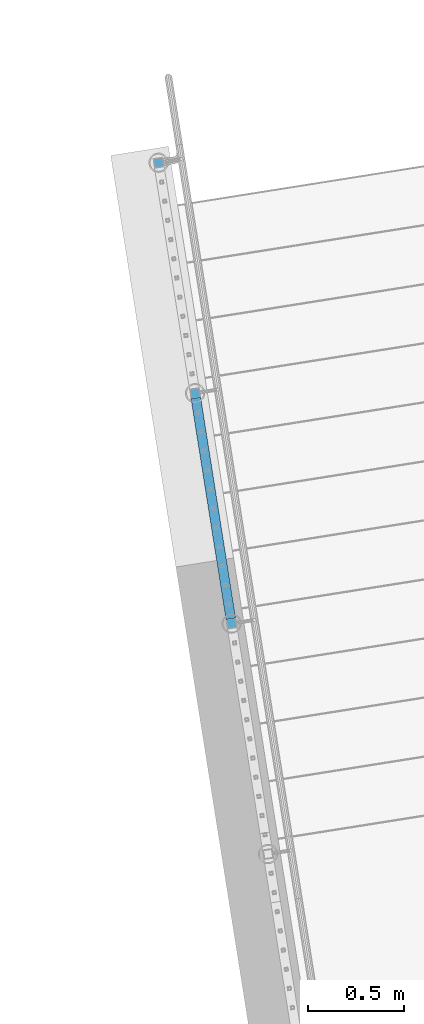
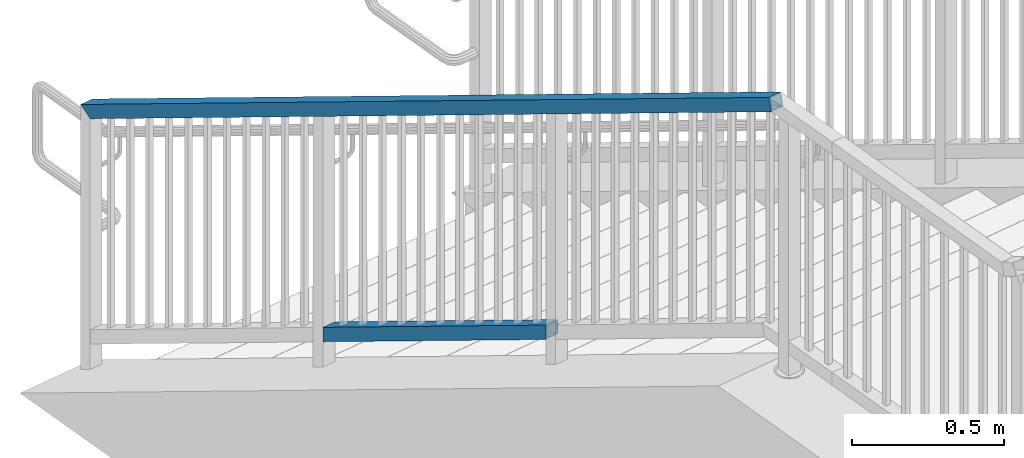
# One storey, part 323 of 975: 2 members.
"""IFC2X3 building model written with IfcOpenShell, lengths in millimetres."""

from ifc_helpers import new_model, si_unit, frame, origin_with_axes, place, context, subcontext, project, spatial, faceted_brep, material, type_object, element, save


model = new_model("IFC2X3")

# Units and contexts
model_context = context("Model", 3, precision=1e-05, world=origin_with_axes())
body_context = subcontext(model_context, "Body", "Model", "MODEL_VIEW")
ifc_project = project(units=[si_unit("LENGTHUNIT", "METRE", prefix="MILLI"), si_unit("AREAUNIT", "SQUARE_METRE"), si_unit("VOLUMEUNIT", "CUBIC_METRE"), si_unit("MASSUNIT", "GRAM", prefix="KILO"), si_unit("TIMEUNIT", "SECOND"), si_unit("PLANEANGLEUNIT", "RADIAN"), si_unit("SOLIDANGLEUNIT", "STERADIAN"), si_unit("THERMODYNAMICTEMPERATUREUNIT", "DEGREE_CELSIUS"), si_unit("LUMINOUSINTENSITYUNIT", "LUMEN")], contexts=[model_context])

# Site, building, storey
site_placement = place(None, origin_with_axes())
site = spatial("IfcSite", under=ifc_project, at=site_placement, CompositionType="ELEMENT")
building_placement = place(site_placement, origin_with_axes())
building = spatial("IfcBuilding", under=site, at=building_placement, Name="Undefined", CompositionType="ELEMENT")
storey_placement = place(building_placement, origin_with_axes())
storey = spatial("IfcBuildingStorey", under=building, at=storey_placement, Name="Undefined", CompositionType="ELEMENT", Elevation=0.0)

# Members
ifc_material = material()
member_type = type_object("IfcMemberType", Name="HSS2X2X.188_TUBES", PredefinedType="NOTDEFINED")
member_1_placement = place(storey_placement, frame((-2502.66257590061, 26405.1281659772, 1525.62946625251), z_axis=(-0.987688340611262, -0.156434464938429, 0.0), x_axis=(-0.136949714005939, 0.864666463037498, -0.48331840802096)))
element("IfcMember", 1, at=member_1_placement, inside=storey, type_object=member_type, material=ifc_material, Name="HANDRAIL", ObjectType="HSS2X2X.188_TUBES", context=body_context, shape_type="Brep", body=[
    faceted_brep([(54.430359559261, 20.6375000000498, -20.6374999999766), (31.6431196181002, -20.6374999999789, -20.6374999999859), (1366.27908560825, -20.6374999989748, -20.6374999998336), (1389.06632582381, 20.6375000010557, -20.6374999998202), (31.6431196296326, -20.6375000000062, 20.6375000000085), (1366.27908561977, -20.6374999989894, 20.6375000001606), (54.430359570797, 20.6375000000207, 20.6375000000166), (1389.06632583534, 20.6375000010394, 20.637500000174), (57.0596564742154, 25.400000000056, -25.3999999999746), (57.0596564884145, 25.4000000000215, 25.4000000000174), (1391.69562278462, 25.4000000010401, 25.4000000001745), (1391.69562277044, 25.4000000010619, -25.399999999818), (29.0138227146781, -25.4000000000106, 25.4000000000065), (1363.64978867316, -25.3999999989974, 25.4000000001583), (29.0138227004791, -25.3999999999778, -25.399999999986), (1363.64978865897, -25.3999999989737, -25.3999999998341)], [[[0, 1, 2, 3]], [[1, 4, 5, 2]], [[4, 6, 7, 5]], [[6, 0, 3, 7]], [[8, 9, 10, 11]], [[9, 12, 13, 10]], [[12, 14, 15, 13]], [[14, 8, 11, 15]], [[13, 15, 11, 10], [5, 7, 3, 2]], [[14, 12, 9, 8], [6, 4, 1, 0]]]),
])
member_2_placement = place(storey_placement, frame((-2323.85798163357, 25276.2003928046, 3063.86370431405), z_axis=(-0.987688340611262, -0.156434464938429, 0.0), x_axis=(-0.136949714005939, 0.864666463037498, -0.48331840802096)))
element("IfcMember", 2, at=member_2_placement, inside=storey, type_object=member_type, material=ifc_material, Name="HANDRAIL", ObjectType="HSS2X2X.188_TUBES", context=body_context, shape_type="Brep", body=[
    faceted_brep([(11.8646579817614, 20.637500000028, -20.6374999999898), (1.22733809156853, -20.6375000000007, -20.6374999999969), (4117.15275135429, -20.6374999977161, -20.6374999994923), (4092.79252137043, 20.6375000022817, -20.6374999994855), (1.22733724917089, -20.6375000000298, 20.6374999999966), (4117.15275136583, -20.6374999977415, 20.6375000005014), (11.8646580322747, 20.6375000000007, 20.6375000000039), (4092.79252138196, 20.6375000022563, 20.6375000005091), (13.0920364064368, 25.4000000000324, -25.3999999999883), (13.0920364686062, 25.3999999999978, 25.4000000000046), (4089.98172561593, 25.4000000022534, 25.4000000005099), (4089.98172560173, 25.4000000022879, -25.3999999994835), (0.0, -25.399999999976, 25.4000000000378), (4119.96354713453, -25.3999999977477, 25.4000000005003), (0.0, -25.400000000016, -25.4000000000196), (4119.96354712033, -25.3999999977132, -25.399999999493)], [[[0, 1, 2, 3]], [[1, 4, 5, 2]], [[4, 6, 7, 5]], [[6, 0, 3, 7]], [[8, 9, 10, 11]], [[9, 12, 13, 10]], [[12, 14, 15, 13]], [[14, 8, 11, 15]], [[13, 15, 11, 10], [5, 7, 3, 2]], [[14, 12, 9, 8], [6, 4, 1, 0]]]),
])

save(model, "model.ifc")
